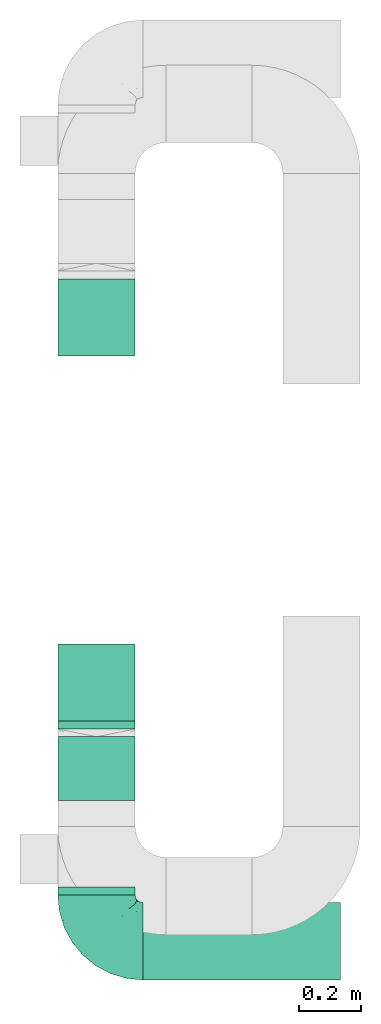
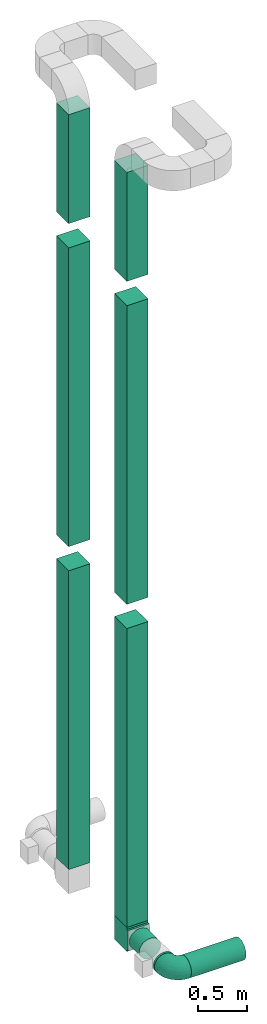
# One storey, part 1 of 5: 9 flow segments, 2 flow fittings.
"""IFC2X3 building model written with IfcOpenShell, lengths in millimetres."""

from ifc_helpers import new_model, entity, si_unit, converted_unit, derived_unit, direction, frame, frame_2d, origin, origin_2d_with_axis, place, context, subcontext, project, spatial, polyline, rectangle, circle, outline, extrude, faceted_brep, source, transform, mapped, type_object, type_shapes, element, save


model = new_model("IFC2X3")

# Units and contexts
model_context = context("Model", 3, precision=0.01, world=origin(), true_north=direction((6.12303176911189e-17, 1.0)))
body_context = subcontext(model_context, "Body", "Model", "MODEL_VIEW")
ifc_project = project(units=[si_unit("LENGTHUNIT", "METRE", prefix="MILLI"), si_unit("AREAUNIT", "SQUARE_METRE"), si_unit("VOLUMEUNIT", "CUBIC_METRE"), converted_unit("PLANEANGLEUNIT", "DEGREE", entity("IfcRatioMeasure", 0.0174532925199433), si_unit("PLANEANGLEUNIT", "RADIAN"), dimensions=[0, 0, 0, 0, 0, 0, 0]), si_unit("MASSUNIT", "GRAM", prefix="KILO"), derived_unit("MASSDENSITYUNIT", [(si_unit("MASSUNIT", "GRAM", prefix="KILO"), 1), (si_unit("LENGTHUNIT", "METRE"), -3)]), si_unit("TIMEUNIT", "SECOND"), si_unit("FREQUENCYUNIT", "HERTZ"), si_unit("THERMODYNAMICTEMPERATUREUNIT", "DEGREE_CELSIUS"), derived_unit("THERMALTRANSMITTANCEUNIT", [(si_unit("MASSUNIT", "GRAM", prefix="KILO"), 1), (si_unit("THERMODYNAMICTEMPERATUREUNIT", "KELVIN"), -1), (si_unit("TIMEUNIT", "SECOND"), -3)]), derived_unit("VOLUMETRICFLOWRATEUNIT", [(si_unit("LENGTHUNIT", "METRE"), 3), (si_unit("TIMEUNIT", "SECOND"), -1)]), si_unit("ELECTRICCURRENTUNIT", "AMPERE"), si_unit("ELECTRICVOLTAGEUNIT", "VOLT"), si_unit("POWERUNIT", "WATT"), si_unit("FORCEUNIT", "NEWTON", prefix="KILO"), si_unit("ILLUMINANCEUNIT", "LUX"), si_unit("LUMINOUSFLUXUNIT", "LUMEN"), si_unit("LUMINOUSINTENSITYUNIT", "CANDELA"), derived_unit("USERDEFINED", [(si_unit("MASSUNIT", "GRAM", prefix="KILO"), -1), (si_unit("LENGTHUNIT", "METRE"), -2), (si_unit("TIMEUNIT", "SECOND"), 3), (si_unit("LUMINOUSFLUXUNIT", "LUMEN"), 1)]), derived_unit("LINEARVELOCITYUNIT", [(si_unit("LENGTHUNIT", "METRE"), 1), (si_unit("TIMEUNIT", "SECOND"), -1)]), si_unit("PRESSUREUNIT", "PASCAL"), derived_unit("USERDEFINED", [(si_unit("LENGTHUNIT", "METRE"), -2), (si_unit("MASSUNIT", "GRAM", prefix="KILO"), 1), (si_unit("TIMEUNIT", "SECOND"), -2)])], contexts=[model_context])

# Site, building, storey
site_placement = place(None, origin())
site = spatial("IfcSite", under=ifc_project, at=site_placement, CompositionType="ELEMENT")
building_placement = place(site_placement, origin())
building = spatial("IfcBuilding", under=site, at=building_placement, CompositionType="ELEMENT")
storey_placement = place(building_placement, frame((0.0, 0.0, 4000.0)))
storey = spatial("IfcBuildingStorey", under=building, at=storey_placement, Name="01 Level", CompositionType="ELEMENT", Elevation=4000.0)

# Flow segments
duct_segment_type_1 = type_object("IfcDuctSegmentType", Name="Round Duct:Air", PredefinedType="NOTDEFINED")
flow_segment_1_placement = place(storey_placement, frame((25345.9632723171, -70384.05691443, 3383.40472776408)))
element("IfcFlowSegment", 1, at=flow_segment_1_placement, inside=storey, type_object=duct_segment_type_1, Name="Round Duct:Air", ObjectType="Round Duct:Air", context=body_context, shape_type="SweptSolid", body=[
    extrude(circle(Radius=125.0, at=origin_2d_with_axis()), frame((0.0, 126.595272235913, 126.595272235916), z_axis=(1.0, 0.0, 0.0), x_axis=(0.0, 1.0, 0.0)), (0.0, 0.0, 1.0), 639.200332511935),
])
flow_segment_2_placement = place(storey_placement, frame((25069.3680000811, -70107.4616421941, 3383.40472776408)))
element("IfcFlowSegment", 2, at=flow_segment_2_placement, inside=storey, type_object=duct_segment_type_1, Name="Round Duct:Air", ObjectType="Round Duct:Air", context=body_context, shape_type="SweptSolid", body=[
    extrude(circle(Radius=125.0, at=origin_2d_with_axis()), frame((126.595272235918, 0.0, 126.595272235916), z_axis=(0.0, 1.0, 0.0), x_axis=(1.0, 0.0, 0.0)), (0.0, 0.0, 1.0), 25.0000000001243),
])
flow_segment_3_placement = place(storey_placement, frame((25069.3680000811, -69802.4616421939, 3383.40472776408)))
element("IfcFlowSegment", 3, at=flow_segment_3_placement, inside=storey, type_object=duct_segment_type_1, Name="Round Duct:Air", ObjectType="Round Duct:Air", context=body_context, shape_type="SweptSolid", body=[
    extrude(circle(Radius=125.0, at=origin_2d_with_axis()), frame((126.595272235918, 0.0, 126.595272235916), z_axis=(0.0, 1.0, 0.0), x_axis=(1.0, 0.0, 0.0)), (0.0, 0.0, 1.0), 206.222057054006),
])

# Flow fitting
duct_fitting_type_1 = type_object("IfcDuctFittingType", Name="Air_Elbow short_Circ", PredefinedType="NOTDEFINED")
shared_shape_1 = source(origin(), body_context, "Body", "Brep", [
    faceted_brep([(-150.0, 0.0, -125.0), (-150.0, -32.3523806378149, -120.740728286134), (-150.0, -62.4999999999998, -108.253175473055), (-150.0, -88.3883476483182, -88.3883476483186), (-150.0, -108.253175473055, -62.5000000000003), (-150.0, -120.740728286133, -32.3523806378155), (-150.0, -123.435651957388, -11.8824030784058), (-150.0, -125.0, 0.0), (-150.0, -123.435651932551, 11.8824032670586), (-150.0, -120.740728286134, 32.3523806378147), (-150.0, -108.253175473055, 62.4999999999996), (-150.0, -88.3883476483188, 88.3883476483181), (-150.0, -62.5000000000004, 108.253175473055), (-150.0, -32.3523806378156, 120.740728286133), (-150.0, 0.0, 125.0), (-150.0, 32.3523806378145, 120.740728286134), (-150.0, 47.426190318907, 114.496951879594), (-150.0, 62.4999999999994, 108.253175473055), (-150.0, 88.3883476483179, 88.3883476483189), (-150.0, 108.253175473054, 62.5000000000006), (-150.0, 120.740728286133, 32.3523806378158), (-150.0, 125.0, 0.0), (-150.0, 120.740728286134, -32.3523806378151), (-150.0, 108.253175473055, -62.4999999999999), (-150.0, 88.3883476483185, -88.3883476483184), (-150.0, 62.5000000000001, -108.253175473055), (-150.0, 32.3523806378152, -120.740728286134), (-32.3523806378144, 150.0, -120.740728286134), (-47.4261903189069, 150.0, -114.496951879594), (-62.4999999999993, 150.0, -108.253175473055), (-88.3883476483177, 150.0, -88.3883476483184), (-108.253175473054, 150.0, -62.4999999999999), (-120.740728286133, 150.0, -32.3523806378151), (-125.0, 150.0, 0.0), (-120.740728286133, 150.0, 32.3523806378158), (-108.253175473054, 150.0, 62.5000000000006), (-88.3883476483171, 150.0, 88.3883476483189), (-62.4999999999986, 150.0, 108.253175473055), (-32.3523806378137, 150.0, 120.740728286134), (0.0, 150.0, 125.0), (32.3523806378164, 150.0, 120.740728286133), (62.5000000000013, 150.0, 108.253175473055), (88.3883476483196, 150.0, 88.3883476483181), (108.253175473056, 150.0, 62.4999999999996), (120.740728286134, 150.0, 32.3523806378147), (123.435651942407, 150.0, 11.8824031922038), (125.0, 150.0, 0.0), (123.435651967915, 150.0, -11.8824029984461), (120.740728286134, 150.0, -32.3523806378155), (108.253175473056, 150.0, -62.5000000000003), (88.3883476483191, 150.0, -88.3883476483186), (62.5000000000006, 150.0, -108.253175473055), (32.3523806378157, 150.0, -120.740728286134), (0.0, 150.0, -125.0), (78.654143383201, -2.78181408039032, 0.0), (76.8166118284912, 4.34215934351885, 36.4784551593461), (61.5542541047513, -23.6180894533453, 0.0), (-134.47520521655, -123.470941174946, 0.0), (-118.950410719399, -121.94188237809, 0.0), (-107.650286082481, -120.828917244489, 0.0), (-104.978291071801, -115.896211779269, 36.0762953828009), (-104.893239881748, -80.8641300661028, 91.4382355521353), (-72.3157335278814, -68.3433914970576, 94.5606631552989), (-98.4001040789566, -53.9628430343128, 109.445004780609), (-96.3501614455635, -119.715952110888, 0.0), (-42.4833938815038, 107.782088248638, 120.147094064889), (-9.85362544116063, 110.378344389653, 124.923923156167), (-65.0280946569744, -106.747383493999, 33.443557785531), (-86.153263795542, -100.695403874887, 61.7233478403087), (-46.6576932994355, -45.2628664218306, 102.931281147801), (-74.6225764033372, -21.2831891292868, 119.356425571857), (-72.3472176796021, 118.598046915095, 106.00707228478), (-30.181321363474, -90.8187429032163, 38.3247326160971), (-70.5561087725814, -111.891411775746, 0.0), (-122.641019976636, -101.950353756475, 70.1921456806148), (-116.029933078324, -22.4446697961388, 122.317161759311), (31.0815829535711, -16.1832151821723, 80.3202993154639), (-6.5545406401204, -44.0646866272317, 85.350831949551), (-3.87227453406602, -60.0293001979925, 66.4690229889152), (-124.863076426312, 35.02364091556, 120.752635411014), (-108.839291442555, 9.81519021738238, 124.939227930759), (-65.2460766604593, 23.6299006304857, 124.981338254694), (-100.878102436648, 43.0002899009219, 120.764526140437), (-19.3649461243935, 39.6901954019144, 123.22697540265), (-40.0496486471489, 1.9751024241996, 120.175633139922), (115.896212240375, 104.978289788922, 36.076293164084), (106.747383973922, 65.0280912143933, 33.4435522492635), (111.891411775747, 70.5561087725829, 0.0), (-128.779008055589, 97.2792215313154, 83.3343675755997), (-129.846276411156, 129.84627642804, 29.3795101662085), (-137.499999999999, 128.349364905389, 0.0), (-119.508978979081, 123.341462022577, 60.2918029167743), (-117.382833556128, 72.4228430829308, 106.251870907854), (-25.6262961621547, 80.1753214783878, 124.782747564482), (-131.548236956176, 110.790620858511, 65.1719471748524), (-8.79719392560859, -75.269004466267, 46.9066376982592), (-35.2869113408269, -83.3156317546561, 59.3885364241187), (80.8641305584726, 104.893240937849, 91.4382352904789), (22.4446672811422, 116.029929681511, 122.317162140699), (53.9628368321699, 98.4001001508859, 109.445007566679), (101.950355286479, 122.641017340516, 70.1921430199164), (-81.9960770469301, 82.9111806812523, 112.506499839482), (121.941882232658, 118.950409242795, 0.0), (71.251669566406, 11.4744102833441, 57.4040159418747), (72.0838963385765, 41.0064832243528, 78.3617835611187), (54.4859475333804, 9.97269301512521, 77.8031341973232), (23.6180894533467, -61.55425410475, 0.0), (32.5558794954592, -52.5906940820025, 23.8275763366719), (5.67366256371018, -73.4168733312184, 25.8218410570659), (-104.061743134415, 104.061741649423, 91.6204401768965), (100.695405783636, 86.1532561367086, 61.7233412541476), (85.8987630246562, 72.298942037013, 77.1305759551526), (45.2628557573736, 46.657677121917, 102.931282428265), (21.2831826839793, 74.6225676704571, 119.356426312895), (-128.349364905388, 137.5, 0.0), (-97.2792212827368, 128.779007172919, 83.3343682018964), (44.4543648263017, -44.4543648263003, 0.0), (-52.705139116163, 62.5335134626551, 123.521409265362), (-44.7620560995991, -104.066871440604, 0.0), (68.3433809087284, 72.3157185192085, 94.5606674302311), (39.0643086961098, -39.0643160658399, 42.9833221935425), (16.162962522349, -57.6081885852494, 46.7813378836038), (87.2978457655956, 45.1469719017519, 60.4141052051649), (-73.6770751262291, 45.4290804428845, 123.301126563982), (91.3605074119029, 20.9901210096052, 0.0), (104.066871440605, 44.7620560996006, 0.0), (90.8187420929716, 30.1813146205812, 38.3247255432369), (24.8419677176115, 18.7098050381526, 104.4628615233), (46.9444181295578, -18.5239913801244, 60.8208891980822), (13.0080717069866, -10.2820614252128, 97.1887902869043), (-29.5778446799892, -20.3201363536925, 110.417514778129), (-1.53394209146154, 80.1817000123714, 124.206375369784), (-65.4894356396677, -87.5368940232825, 72.0830916827234), (-3.04954297208558, 3.04952905280945, 110.823842282024), (9.92439824324807, 37.6446897703782, 116.445568419899), (2.7818140803917, -78.6541433831998, 0.0), (59.4075113977493, -18.3919768641063, 39.1397493302004), (-41.0065082221364, -72.0839038715865, 78.3617888442077), (-20.9901210096037, -91.3605074119017, 0.0), (119.715952110889, 96.3501614455651, 0.0), (-39.6901857853554, 19.3649451890522, -123.226974224734), (-62.5335140350356, 52.7051321522757, -123.521410009679), (-23.6299179988057, 65.2460778291534, -124.981338515222), (52.5906917601974, -32.5558816629036, -23.8275777472421), (73.4168733742841, -5.67366166885961, -25.8218433127719), (-110.378347073661, 9.85362190254904, -124.923923249535), (-35.0236472156293, 124.863059021426, -120.752634758897), (-107.782088925523, 42.4833910778036, -120.147094743061), (-104.978289397083, -115.896211531471, -36.0762952658108), (-86.1532622275364, -100.695403598284, -61.7233476308542), (-65.0280943433708, -106.747382926782, -33.4435593699909), (-129.846276430226, 129.846276387071, -29.3795102302433), (-110.790620399346, 131.548235360156, -65.1719489671012), (-123.341462756194, 119.508979301124, -60.291801599493), (-104.061744765902, 104.061740157582, -91.6204400852508), (-128.779008894392, 97.2792211868359, -83.3343675827014), (53.9628420250463, 98.4000971565888, -109.445004383699), (-118.598049105409, 72.3472165670435, -106.007072416171), (-82.9111719502085, 81.9960693312282, -112.50650546776), (-122.641019448242, -101.950353750649, -70.1921456050946), (-104.893238223024, -80.8641303146933, -91.4382350282511), (-98.4001019855057, -53.9628440035923, -109.445003978822), (80.8641292666627, 104.893234920637, -91.4382353967358), (-11.4744255033641, -71.2516789045734, -57.4040162551542), (-41.0065049684125, -72.0839032542554, -78.3617877513776), (-9.97270838371827, -54.485960500352, -77.8031316627462), (-4.34216444876671, -76.8166149897799, -36.4784554826068), (-80.1753222808587, 25.6262887954871, -124.782747920507), (-116.029931420384, -22.4446712385047, -122.317161393809), (68.3433887340013, 72.3157292909759, -94.5606641780198), (45.2628607882706, 46.6576825738772, -102.931281121668), (22.4446699556419, 116.029925989706, -122.317161437833), (-9.8151830458522, 108.839262459516, -124.939228400111), (-72.298953284581, -85.8987604849819, -77.1305835190378), (-97.2792209116865, 128.779005996318, -83.3343690779209), (-46.6576894105135, -45.2628676819038, -102.931279126956), (-72.3157308447408, -68.3433918222031, -94.5606621128927), (-72.422840670004, 117.382841409987, -106.251870399877), (21.2831853090833, 74.6225640045938, -119.356425105916), (101.950353353368, 122.641019823701, -70.1921462468134), (-43.0003002529277, 100.878091329174, -120.764524865091), (16.1832033989244, -31.0815970254922, -80.3202964529749), (44.0646797153192, 6.55452919959333, -85.3508306205825), (60.0292953493994, 3.87226817055985, -66.4690235395615), (115.896211010696, 104.978286786289, -36.0762955232767), (106.747381524869, 65.0280939101863, -33.4435636729749), (100.695402688448, 86.1532621979624, -61.7233491707037), (-1.97512261791953, 40.0496336831204, -120.175635225652), (83.315631357607, 35.2869127496766, -59.388538235289), (90.8187416032175, 30.181318578684, -38.3247323782698), (75.2690016288807, 8.79719117487841, -46.9066400280846), (18.5239820708271, -46.9444270147629, -60.8208879439308), (57.6081840561054, -16.162966744892, -46.7813401074288), (39.0643108807276, -39.0643133486842, -42.9833232218422), (-74.6225723501512, -21.2831916140966, -119.356424356291), (-45.1469861494655, -87.2978481709874, -60.4141116504016), (-45.4290965712264, 73.6770713110896, -123.301124768617), (-30.1813201883898, -90.818742779246, -38.3247313356157), (-18.7098212867178, -24.8419796072181, -104.462861687025), (10.2820459472016, -13.0080933749158, -97.1887865677227), (20.3201251027192, 29.5778424846975, -110.417518980415), (-80.1817048843535, 1.5339337664806, -124.206374751548), (87.5368918123803, 65.4894359750046, -72.0830947930252), (-3.04953343548765, 3.04952712079592, -110.823838051094), (-37.6446965781717, -9.92440491577136, -116.445567816425), (18.3919716152399, -59.4075155656008, -39.1397494553499), (72.083900742128, 41.0065066004899, -78.361791447751)], [[[0, 1, 2, 3, 4, 5, 6, 7, 8, 9, 10, 11, 12, 13, 14, 15, 16, 17, 18, 19, 20, 21, 22, 23, 24, 25, 26]], [[27, 28, 29, 30, 31, 32, 33, 34, 35, 36, 37, 38, 39, 40, 41, 42, 43, 44, 45, 46, 47, 48, 49, 50, 51, 52, 53]], [[54, 55, 56]], [[9, 8, 7, 57, 58, 59]], [[60, 10, 9]], [[61, 62, 63]], [[60, 59, 64]], [[38, 65, 66]], [[60, 67, 68]], [[12, 11, 61]], [[63, 12, 61]], [[63, 69, 70]], [[37, 36, 71]], [[72, 68, 67]], [[60, 73, 67]], [[11, 10, 74]], [[37, 71, 65]], [[13, 75, 14]], [[76, 77, 78]], [[17, 16, 15, 79]], [[80, 81, 82]], [[83, 81, 84]], [[85, 86, 87]], [[18, 88, 19]], [[89, 21, 20]], [[21, 89, 90]], [[89, 91, 34]], [[63, 62, 69]], [[17, 92, 18]], [[93, 66, 65]], [[19, 88, 94]], [[63, 70, 75]], [[95, 96, 72]], [[74, 60, 68]], [[41, 97, 42]], [[13, 12, 63]], [[40, 98, 99]], [[43, 42, 100]], [[65, 71, 101]], [[41, 40, 99]], [[85, 102, 44]], [[103, 104, 105]], [[41, 99, 97]], [[85, 44, 43]], [[106, 107, 108]], [[79, 92, 17]], [[102, 46, 45, 44]], [[71, 109, 101]], [[85, 110, 86]], [[97, 111, 110]], [[33, 89, 34]], [[112, 99, 113]], [[114, 89, 33]], [[94, 20, 19]], [[115, 91, 109]], [[116, 107, 106]], [[117, 81, 83]], [[91, 35, 34]], [[36, 35, 115]], [[118, 72, 67]], [[15, 14, 80]], [[112, 104, 119]], [[65, 38, 37]], [[66, 39, 38]], [[107, 120, 121]], [[122, 86, 110]], [[39, 98, 40]], [[75, 80, 14]], [[100, 85, 43]], [[123, 81, 117]], [[82, 123, 101]], [[88, 92, 109]], [[124, 125, 126]], [[127, 105, 112]], [[121, 128, 76]], [[77, 129, 130]], [[115, 71, 36]], [[109, 92, 101]], [[93, 65, 117]], [[66, 131, 98]], [[119, 97, 99]], [[100, 97, 110]], [[74, 61, 11]], [[132, 68, 96]], [[80, 70, 81]], [[84, 81, 70]], [[133, 134, 83]], [[93, 131, 66]], [[135, 106, 108]], [[72, 108, 95]], [[110, 111, 122]], [[136, 116, 56]], [[134, 112, 113]], [[112, 134, 127]], [[77, 69, 137]], [[84, 130, 133]], [[96, 78, 137]], [[129, 76, 127]], [[82, 101, 92]], [[65, 101, 117]], [[66, 98, 39]], [[99, 98, 113]], [[63, 75, 13]], [[80, 75, 70]], [[91, 115, 35]], [[71, 115, 109]], [[92, 88, 18]], [[94, 109, 91]], [[86, 125, 87]], [[135, 108, 138]], [[125, 86, 126]], [[87, 139, 85]], [[117, 83, 93]], [[83, 134, 131]], [[83, 131, 93]], [[98, 131, 113]], [[109, 94, 88]], [[94, 91, 89]], [[9, 59, 60]], [[102, 85, 139]], [[90, 89, 114]], [[89, 20, 94]], [[60, 74, 10]], [[61, 74, 68]], [[97, 100, 42]], [[85, 100, 110]], [[82, 92, 79]], [[15, 80, 79]], [[80, 82, 79]], [[121, 108, 107]], [[136, 107, 116]], [[112, 119, 99]], [[95, 108, 121]], [[108, 72, 138]], [[78, 95, 121]], [[95, 78, 96]], [[76, 78, 121]], [[137, 78, 77]], [[132, 96, 137]], [[68, 72, 96]], [[62, 132, 137]], [[61, 68, 132]], [[128, 120, 136]], [[121, 120, 128]], [[103, 128, 136]], [[128, 103, 105]], [[55, 103, 136]], [[122, 103, 126]], [[112, 105, 104]], [[128, 105, 76]], [[55, 126, 103]], [[136, 120, 107]], [[111, 119, 104]], [[119, 111, 97]], [[122, 111, 104]], [[103, 122, 104]], [[122, 126, 86]], [[132, 62, 61]], [[69, 62, 137]], [[101, 123, 117]], [[82, 81, 123]], [[130, 70, 69]], [[83, 84, 133]], [[70, 130, 84]], [[77, 130, 69]], [[134, 133, 127]], [[131, 134, 113]], [[129, 127, 133]], [[105, 127, 76]], [[130, 129, 133]], [[77, 76, 129]], [[72, 118, 138]], [[55, 124, 126]], [[73, 60, 64]], [[73, 118, 67]], [[56, 55, 136]], [[124, 55, 54]], [[140, 141, 142]], [[56, 143, 144]], [[145, 0, 26]], [[28, 27, 146, 29]], [[25, 147, 26]], [[148, 149, 150]], [[90, 151, 21]], [[152, 32, 31]], [[153, 154, 155]], [[56, 116, 143]], [[155, 24, 23]], [[52, 51, 156]], [[147, 157, 158]], [[22, 153, 23]], [[4, 148, 5]], [[25, 24, 157]], [[57, 7, 6, 5, 58]], [[159, 148, 4]], [[160, 2, 161]], [[51, 50, 162]], [[160, 3, 2]], [[163, 164, 165]], [[4, 3, 159]], [[135, 166, 106]], [[167, 145, 147]], [[2, 1, 161]], [[168, 161, 1]], [[157, 154, 158]], [[156, 169, 170]], [[151, 90, 114]], [[171, 172, 53]], [[33, 32, 151]], [[160, 173, 149]], [[31, 174, 152]], [[175, 164, 176]], [[146, 177, 29]], [[30, 174, 31]], [[157, 147, 25]], [[52, 171, 53]], [[156, 178, 171]], [[50, 49, 179]], [[172, 142, 180]], [[181, 182, 183]], [[177, 30, 29]], [[27, 53, 172]], [[0, 168, 1]], [[170, 178, 156]], [[184, 185, 186]], [[140, 142, 187]], [[188, 189, 190]], [[26, 147, 145]], [[51, 162, 156]], [[186, 185, 189]], [[191, 192, 193]], [[102, 139, 184]], [[48, 102, 184]], [[151, 153, 22]], [[184, 49, 48]], [[175, 161, 194]], [[169, 156, 162]], [[144, 189, 124]], [[148, 150, 73]], [[184, 87, 185]], [[114, 33, 151]], [[179, 184, 186]], [[195, 150, 149]], [[180, 142, 196]], [[180, 196, 158]], [[174, 177, 154]], [[118, 150, 197]], [[198, 165, 175]], [[163, 165, 191]], [[182, 199, 200]], [[155, 157, 24]], [[154, 177, 158]], [[167, 147, 141]], [[145, 201, 168]], [[176, 160, 161]], [[159, 160, 149]], [[179, 162, 50]], [[202, 186, 188]], [[172, 178, 142]], [[187, 142, 178]], [[203, 204, 140]], [[167, 201, 145]], [[54, 56, 144]], [[189, 144, 190]], [[149, 173, 195]], [[205, 116, 106]], [[204, 175, 194]], [[175, 204, 198]], [[182, 170, 206]], [[187, 200, 203]], [[188, 183, 206]], [[199, 181, 198]], [[180, 158, 177]], [[147, 158, 141]], [[145, 168, 0]], [[161, 168, 194]], [[156, 171, 52]], [[172, 171, 178]], [[153, 155, 23]], [[157, 155, 154]], [[177, 174, 30]], [[152, 154, 153]], [[150, 118, 73]], [[87, 184, 139]], [[166, 138, 197]], [[73, 64, 148]], [[141, 140, 167]], [[140, 204, 201]], [[140, 201, 167]], [[168, 201, 194]], [[154, 152, 174]], [[152, 153, 151]], [[148, 64, 59, 58]], [[5, 148, 58]], [[47, 46, 102, 48]], [[151, 32, 152]], [[151, 22, 21]], [[184, 179, 49]], [[162, 179, 186]], [[160, 159, 3]], [[148, 159, 149]], [[180, 177, 146]], [[27, 172, 146]], [[172, 180, 146]], [[143, 193, 192]], [[143, 116, 205]], [[143, 192, 144]], [[190, 144, 192]], [[189, 125, 124]], [[183, 190, 192]], [[190, 183, 188]], [[181, 183, 192]], [[206, 183, 182]], [[202, 188, 206]], [[186, 189, 188]], [[169, 202, 206]], [[162, 186, 202]], [[175, 176, 161]], [[191, 193, 205]], [[191, 205, 163]], [[192, 191, 181]], [[166, 163, 205]], [[195, 163, 197]], [[175, 165, 164]], [[191, 165, 181]], [[166, 197, 163]], [[205, 193, 143]], [[173, 176, 164]], [[176, 173, 160]], [[195, 173, 164]], [[163, 195, 164]], [[195, 197, 150]], [[202, 169, 162]], [[170, 169, 206]], [[142, 141, 196]], [[158, 196, 141]], [[200, 178, 170]], [[140, 187, 203]], [[178, 200, 187]], [[182, 200, 170]], [[204, 203, 198]], [[201, 204, 194]], [[199, 198, 203]], [[165, 198, 181]], [[200, 199, 203]], [[182, 181, 199]], [[125, 189, 185]], [[54, 144, 124]], [[138, 118, 197]], [[87, 125, 185]], [[106, 166, 205]], [[138, 166, 135]]]),
])
type_shapes(duct_fitting_type_1, [shared_shape_1])
flow_fitting_1_placement = place(storey_placement, frame((25195.9632723171, -70257.4616421941, 3510.0), z_axis=(0.0, 0.0, 1.0), x_axis=(0.0, -1.0, 0.0)))
element("IfcFlowFitting", 4, at=flow_fitting_1_placement, inside=storey, type_object=duct_fitting_type_1, Name="elbow_short_001:Air_Elbow short_Circ", ObjectType="elbow_short_001:Air_Elbow short_Circ", context=body_context, shape_type="MappedRepresentation", body=[
    mapped(shared_shape_1, transform((0.0, 0.0, 0.0), scale=1.0)),
])

# Flow segments
duct_segment_type_2 = type_object("IfcDuctSegmentType", Name="Rectangular Duct:Air", PredefinedType="NOTDEFINED")
flow_segment_4_placement = place(storey_placement, frame((25070.9632723171, -69546.2395851399, 11660.0)))
element("IfcFlowSegment", 5, at=flow_segment_4_placement, inside=storey, type_object=duct_segment_type_2, Name="Rectangular Duct:Air", ObjectType="Rectangular Duct:Air", context=body_context, shape_type="SweptSolid", body=[
    extrude(rectangle(XDim=250.000000000004, YDim=250.000000000004, at=frame_2d((0.0, 4.33431068813661e-12), x_axis=(1.0, 0.0))), frame((125.0, 125.0, 0.0), z_axis=(0.0, 0.0, 1.0), x_axis=(-1.0, 0.0, 0.0)), (0.0, 0.0, 1.0), 1350.95052634352),
])
flow_segment_5_placement = place(storey_placement, frame((25070.9632723171, -68366.23958514, 11660.0)))
element("IfcFlowSegment", 6, at=flow_segment_5_placement, inside=storey, type_object=duct_segment_type_2, Name="Rectangular Duct:Air", ObjectType="Rectangular Duct:Air", context=body_context, shape_type="SweptSolid", body=[
    extrude(rectangle(XDim=249.999999999995, YDim=249.999999999999, at=frame_2d((4.32720526077901e-12, 0.0), x_axis=(1.0, 0.0))), frame((125.0, 125.0, 0.0), z_axis=(0.0, 0.0, 1.0), x_axis=(0.0, -1.0, 0.0)), (0.0, 0.0, 1.0), 1350.95052634352),
])
flow_segment_6_placement = place(storey_placement, frame((25070.9632723171, -68366.23958514, 3660.0)))
element("IfcFlowSegment", 7, at=flow_segment_6_placement, inside=storey, type_object=duct_segment_type_2, Name="Rectangular Duct:Air", ObjectType="Rectangular Duct:Air", context=body_context, shape_type="SweptSolid", body=[
    extrude(rectangle(XDim=250.000000000004, YDim=250.000000000004, at=frame_2d((0.0, 4.33431068813661e-12), x_axis=(1.0, 0.0))), frame((125.0, 125.0, 0.0)), (0.0, 0.0, 1.0), 3700.0),
])
flow_segment_7_placement = place(storey_placement, frame((25070.9632723171, -69546.2395851399, 3660.0)))
element("IfcFlowSegment", 8, at=flow_segment_7_placement, inside=storey, type_object=duct_segment_type_2, Name="Rectangular Duct:Air", ObjectType="Rectangular Duct:Air", context=body_context, shape_type="SweptSolid", body=[
    extrude(rectangle(XDim=249.999999999995, YDim=249.999999999999, at=frame_2d((-4.32720526077901e-12, 0.0), x_axis=(1.0, 0.0))), frame((125.0, 125.0, 0.0), z_axis=(0.0, 0.0, 1.0), x_axis=(0.0, -1.0, 0.0)), (0.0, 0.0, 1.0), 3700.0),
])
flow_segment_8_placement = place(storey_placement, frame((25070.9632723171, -68366.23958514, 7660.0)))
element("IfcFlowSegment", 9, at=flow_segment_8_placement, inside=storey, type_object=duct_segment_type_2, Name="Rectangular Duct:Air", ObjectType="Rectangular Duct:Air", context=body_context, shape_type="SweptSolid", body=[
    extrude(rectangle(XDim=249.999999999995, YDim=249.999999999999, at=frame_2d((4.32720526077901e-12, 0.0), x_axis=(1.0, 0.0))), frame((125.0, 125.0, 0.0), z_axis=(0.0, 0.0, 1.0), x_axis=(0.0, -1.0, 0.0)), (0.0, 0.0, 1.0), 3700.0),
])
flow_segment_9_placement = place(storey_placement, frame((25070.9632723171, -69546.2395851399, 7660.0)))
element("IfcFlowSegment", 10, at=flow_segment_9_placement, inside=storey, type_object=duct_segment_type_2, Name="Rectangular Duct:Air", ObjectType="Rectangular Duct:Air", context=body_context, shape_type="SweptSolid", body=[
    extrude(rectangle(XDim=249.999999999995, YDim=249.999999999999, at=frame_2d((-4.32720526077901e-12, 0.0), x_axis=(1.0, 0.0))), frame((125.0, 125.0, 0.0), z_axis=(0.0, 0.0, 1.0), x_axis=(0.0, -1.0, 0.0)), (0.0, 0.0, 1.0), 3700.0),
])

# Flow fitting
duct_fitting_type_2 = type_object("IfcDuctFittingType", Name="Air_Rect", PredefinedType="NOTDEFINED")
shared_shape_2 = source(origin(), body_context, "Body", "SweptSolid", [
    extrude(outline(polyline([(-150.0, 56.2500000000001), (-150.0, -193.75), (150.0, -193.75), (150.0, 56.25), (125.0, 56.25), (125.0, 81.2499999999995), (-125.0, 81.2500000000003), (-125.0, 56.2500000000001), (-150.0, 56.2500000000001)])), frame((0.0, -68.75, -125.0), z_axis=(0.0, 0.0, -1.0), x_axis=(1.0, 0.0, 0.0)), (0.0, 0.0, -1.0), 250.0),
])
type_shapes(duct_fitting_type_2, [shared_shape_2])
flow_fitting_2_placement = place(storey_placement, frame((25195.9632723171, -69421.2395851399, 3510.0), z_axis=(1.0, 0.0, 0.0), x_axis=(0.0, 0.0, -1.0)))
element("IfcFlowFitting", 11, at=flow_fitting_2_placement, inside=storey, type_object=duct_fitting_type_2, Name="1_001:Air_Rect", ObjectType="1_001:Air_Rect", context=body_context, shape_type="MappedRepresentation", body=[
    mapped(shared_shape_2, transform((0.0, 0.0, 0.0), scale=1.0)),
])

save(model, "model.ifc")
